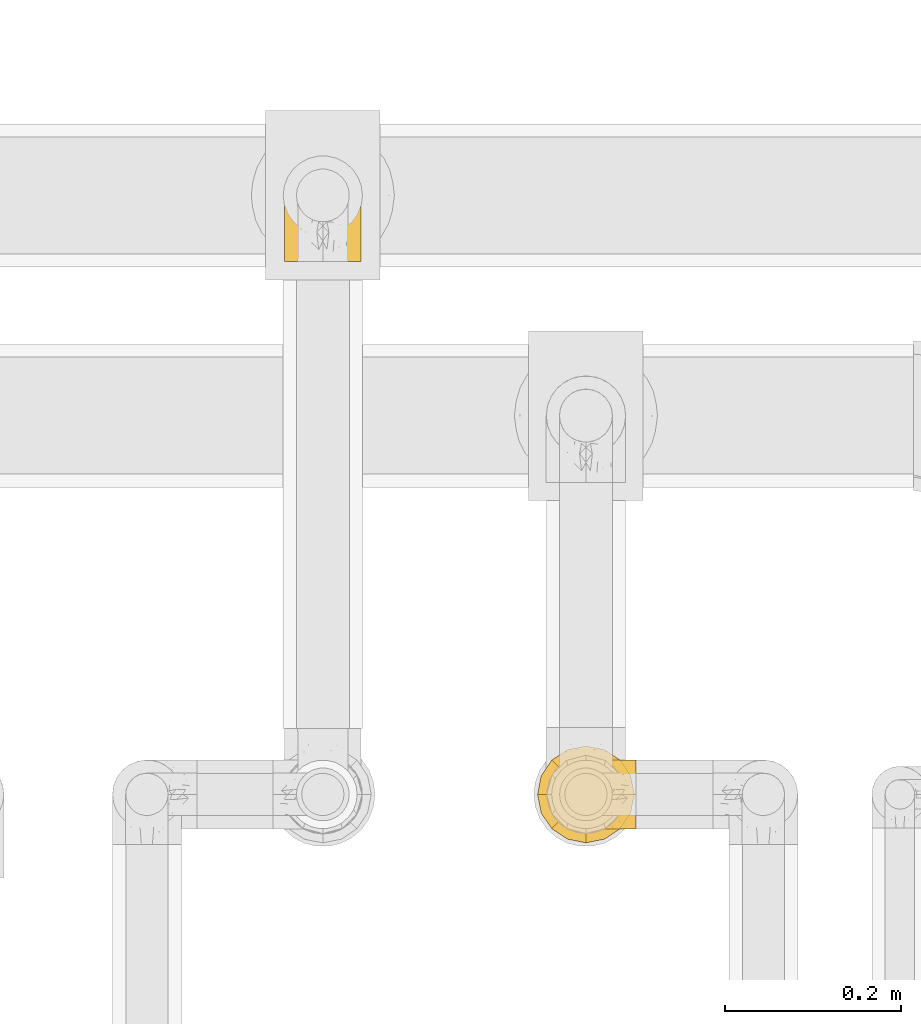
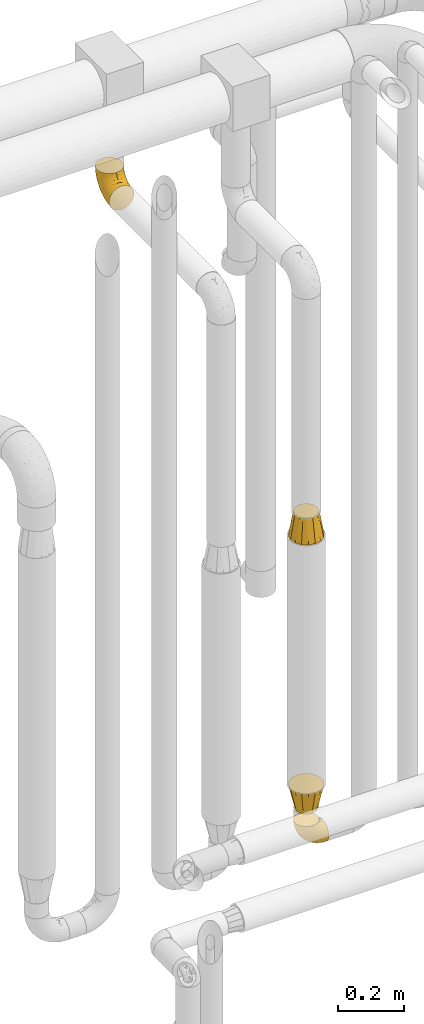
# One storey, part 479 of 827: 4 coverings.
"""IFC2X3 building model written with IfcOpenShell, lengths in millimetres."""

from ifc_helpers import new_model, entity, si_unit, converted_unit, derived_unit, direction, frame, origin, place, context, subcontext, project, spatial, faceted_brep, element, save


model = new_model("IFC2X3")

# Units and contexts
model_context = context("Model", 3, precision=0.01, world=origin(), true_north=direction((6.12303176911189e-17, 1.0)))
body_context = subcontext(model_context, "Body", "Model", "MODEL_VIEW")
ifc_project = project(units=[si_unit("LENGTHUNIT", "METRE", prefix="MILLI"), si_unit("AREAUNIT", "SQUARE_METRE"), si_unit("VOLUMEUNIT", "CUBIC_METRE"), converted_unit("PLANEANGLEUNIT", "DEGREE", entity("IfcRatioMeasure", 0.0174532925199433), si_unit("PLANEANGLEUNIT", "RADIAN"), dimensions=[0, 0, 0, 0, 0, 0, 0]), si_unit("MASSUNIT", "GRAM", prefix="KILO"), derived_unit("MASSDENSITYUNIT", [(si_unit("MASSUNIT", "GRAM", prefix="KILO"), 1), (si_unit("LENGTHUNIT", "METRE"), -3)]), derived_unit("MOMENTOFINERTIAUNIT", [(si_unit("LENGTHUNIT", "METRE"), 4)]), si_unit("TIMEUNIT", "SECOND"), si_unit("FREQUENCYUNIT", "HERTZ"), si_unit("THERMODYNAMICTEMPERATUREUNIT", "DEGREE_CELSIUS"), derived_unit("THERMALTRANSMITTANCEUNIT", [(si_unit("MASSUNIT", "GRAM", prefix="KILO"), 1), (si_unit("THERMODYNAMICTEMPERATUREUNIT", "KELVIN"), -1), (si_unit("TIMEUNIT", "SECOND"), -3)]), derived_unit("VOLUMETRICFLOWRATEUNIT", [(si_unit("LENGTHUNIT", "METRE"), 3), (si_unit("TIMEUNIT", "SECOND"), -1)]), derived_unit("MASSFLOWRATEUNIT", [(si_unit("MASSUNIT", "GRAM", prefix="KILO"), 1), (si_unit("TIMEUNIT", "SECOND"), -1)]), derived_unit("ROTATIONALFREQUENCYUNIT", [(si_unit("TIMEUNIT", "SECOND"), -1)]), si_unit("ELECTRICCURRENTUNIT", "AMPERE"), si_unit("ELECTRICVOLTAGEUNIT", "VOLT"), si_unit("POWERUNIT", "WATT"), si_unit("FORCEUNIT", "NEWTON", prefix="KILO"), si_unit("ILLUMINANCEUNIT", "LUX"), si_unit("LUMINOUSFLUXUNIT", "LUMEN"), si_unit("LUMINOUSINTENSITYUNIT", "CANDELA"), derived_unit("USERDEFINED", [(si_unit("MASSUNIT", "GRAM", prefix="KILO"), -1), (si_unit("LENGTHUNIT", "METRE"), -2), (si_unit("TIMEUNIT", "SECOND"), 3), (si_unit("LUMINOUSFLUXUNIT", "LUMEN"), 1)]), derived_unit("LINEARVELOCITYUNIT", [(si_unit("LENGTHUNIT", "METRE"), 1), (si_unit("TIMEUNIT", "SECOND"), -1)]), si_unit("PRESSUREUNIT", "PASCAL"), derived_unit("USERDEFINED", [(si_unit("LENGTHUNIT", "METRE"), -2), (si_unit("MASSUNIT", "GRAM", prefix="KILO"), 1), (si_unit("TIMEUNIT", "SECOND"), -2)]), derived_unit("LINEARFORCEUNIT", [(si_unit("MASSUNIT", "GRAM", prefix="KILO"), 1), (si_unit("LENGTHUNIT", "METRE"), 1), (si_unit("TIMEUNIT", "SECOND"), -2), (si_unit("LENGTHUNIT", "METRE"), -1)]), derived_unit("PLANARFORCEUNIT", [(si_unit("MASSUNIT", "GRAM", prefix="KILO"), 1), (si_unit("LENGTHUNIT", "METRE"), 1), (si_unit("TIMEUNIT", "SECOND"), -2), (si_unit("LENGTHUNIT", "METRE"), -2)])], contexts=[model_context])

# Site, building, storey
site_placement = place(None, origin())
site = spatial("IfcSite", under=ifc_project, at=site_placement, CompositionType="ELEMENT")
building_placement = place(site_placement, origin())
building = spatial("IfcBuilding", under=site, at=building_placement, CompositionType="ELEMENT")
storey_placement = place(building_placement, frame((0.0, 0.0, 28200.0)))
storey = spatial("IfcBuildingStorey", under=building, at=storey_placement, Name="08", CompositionType="ELEMENT", Elevation=28200.0)

# Coverings
covering_1_placement = place(storey_placement, frame((59555.92, 17459.25, 359.25)))
element("IfcCovering", 1, at=covering_1_placement, inside=storey, Name=":ADSK_", ObjectType=":ADSK_", PredefinedType="INSULATION", context=body_context, shape_type="Brep", body=[
    faceted_brep([(40.75, 79.9, 97.75), (32.03, 78.91, 97.75), (23.75, 76.02, 97.75), (16.33, 71.35, 97.75), (10.13, 65.15, 97.75), (5.47, 57.73, 97.75), (2.58, 49.45, 97.75), (1.6, 40.75, 97.75), (2.58, 32.03, 97.75), (5.48, 23.75, 97.75), (10.14, 16.33, 97.75), (16.34, 10.13, 97.75), (23.76, 5.47, 97.75), (32.04, 2.58, 97.75), (40.75, 1.6, 97.75), (43.94, 1.96, 97.75), (49.46, 2.58, 97.75), (53.6, 4.03, 97.75), (57.74, 5.48, 97.75), (65.16, 10.14, 97.75), (71.36, 16.34, 97.75), (76.02, 23.76, 97.75), (78.91, 32.04, 97.75), (79.9, 40.75, 97.75), (78.91, 49.46, 97.75), (76.02, 57.74, 97.75), (71.35, 65.16, 97.75), (65.15, 71.36, 97.75), (57.73, 76.02, 97.75), (49.45, 78.91, 97.75), (43.94, 79.54, 97.75), (97.75, 13.06, 68.43), (97.75, 6.84, 60.32), (97.75, 2.93, 50.88), (97.75, 2.44, 47.16), (97.75, 2.02, 43.95), (97.75, 1.6, 40.75), (97.75, 2.93, 30.61), (97.75, 6.84, 21.17), (97.75, 13.06, 13.06), (97.75, 21.17, 6.84), (97.75, 30.61, 2.93), (97.75, 40.75, 1.6), (97.75, 50.88, 2.93), (97.75, 60.32, 6.84), (97.75, 68.43, 13.06), (97.75, 74.65, 21.17), (97.75, 78.56, 30.61), (97.75, 79.9, 40.75), (97.75, 79.05, 47.16), (97.75, 78.56, 50.88), (97.75, 74.65, 60.32), (97.75, 68.43, 68.43), (97.75, 60.32, 74.65), (97.75, 50.88, 78.56), (97.75, 40.75, 79.9), (97.75, 30.61, 78.56), (97.75, 21.17, 74.65), (30.59, 40.75, 30.59), (19.96, 40.75, 41.23), (31.39, 53.99, 31.39), (41.23, 40.75, 19.96), (68.03, 40.75, 6.3), (73.86, 47.49, 5.21), (78.49, 40.75, 4.64), (51.06, 51.52, 15.42), (61.05, 61.86, 15.6), (74.96, 54.43, 6.88), (80.64, 63.37, 10.45), (35.94, 79.25, 80.79), (55.44, 77.04, 39.87), (78.19, 75.79, 25.91), (58.08, 72.61, 28.57), (78.4, 78.93, 35.0), (74.65, 70.12, 18.15), (14.61, 66.7, 74.57), (20.05, 72.7, 80.38), (24.25, 70.21, 59.65), (43.81, 78.8, 59.36), (45.08, 79.9, 75.93), (48.17, 79.9, 71.31), (51.26, 79.9, 66.69), (54.35, 79.9, 62.06), (57.44, 79.9, 57.44), (40.25, 74.44, 46.63), (6.22, 52.47, 74.83), (61.23, 79.33, 45.67), (62.06, 79.9, 54.35), (66.69, 79.9, 51.26), (71.31, 79.9, 48.17), (75.93, 79.9, 45.08), (13.08, 48.94, 54.03), (14.98, 58.78, 58.15), (8.5, 60.43, 80.8), (4.64, 40.75, 78.49), (36.67, 62.02, 31.82), (22.97, 57.53, 43.52), (41.46, 79.9, 94.17), (42.17, 79.9, 90.6), (43.59, 79.9, 83.46), (25.24, 64.12, 47.16), (31.25, 75.76, 64.11), (26.96, 76.65, 81.54), (38.0, 68.92, 38.43), (50.65, 66.73, 25.45), (54.63, 40.75, 13.13), (6.3, 40.75, 68.03), (83.46, 79.9, 43.59), (87.03, 79.9, 42.88), (90.6, 79.9, 42.17), (13.13, 40.75, 54.63), (91.79, 63.86, 73.05), (87.2, 69.15, 69.6), (87.5, 78.65, 51.66), (89.79, 72.98, 63.89), (88.45, 76.47, 57.82), (81.77, 76.82, 59.13), (79.81, 79.05, 52.25), (73.84, 79.09, 54.86), (91.84, 51.28, 79.38), (86.62, 51.03, 82.07), (85.12, 40.75, 85.12), (91.15, 40.75, 82.63), (80.84, 49.93, 89.2), (78.96, 58.53, 86.06), (71.38, 69.86, 81.78), (76.81, 65.19, 81.63), (74.29, 70.75, 76.19), (48.29, 79.25, 90.86), (49.97, 79.11, 85.89), (92.85, 57.89, 76.5), (77.55, 55.93, 92.32), (62.05, 78.06, 70.11), (70.85, 75.39, 69.83), (65.52, 78.16, 65.67), (80.71, 66.62, 76.0), (77.97, 73.14, 68.84), (66.14, 71.07, 91.37), (57.01, 78.32, 76.37), (64.57, 73.93, 83.17), (56.53, 77.25, 85.98), (51.07, 79.26, 79.95), (81.85, 60.3, 81.01), (82.63, 40.75, 91.15), (72.53, 65.72, 88.52), (67.69, 74.5, 75.86), (86.44, 60.62, 77.41), (82.44, 73.96, 64.86), (75.97, 77.3, 60.69), (70.39, 77.83, 62.7), (92.85, 23.6, 76.5), (88.99, 17.57, 73.85), (41.46, 1.6, 94.17), (42.17, 1.6, 90.6), (43.59, 1.6, 83.46), (80.84, 31.57, 89.2), (78.97, 22.97, 86.06), (77.55, 25.57, 92.32), (72.54, 15.78, 88.52), (83.46, 1.6, 43.59), (90.6, 1.6, 42.17), (94.17, 1.6, 41.46), (87.2, 12.34, 69.6), (82.6, 7.57, 64.84), (89.34, 8.85, 64.5), (80.74, 2.63, 52.81), (81.77, 4.67, 59.13), (74.04, 2.36, 54.5), (75.93, 1.6, 45.08), (87.5, 2.84, 51.66), (51.07, 2.24, 79.95), (48.17, 1.6, 71.31), (57.03, 3.18, 76.38), (74.31, 10.74, 76.18), (80.61, 15.18, 76.44), (77.09, 16.42, 81.43), (91.84, 30.21, 79.38), (79.19, 9.98, 70.71), (86.62, 30.46, 82.07), (66.15, 10.43, 91.37), (71.84, 12.05, 81.89), (56.55, 4.24, 85.98), (64.59, 7.56, 83.17), (62.05, 3.43, 70.11), (49.99, 2.38, 85.9), (45.08, 1.6, 75.93), (70.39, 3.66, 62.7), (76.36, 4.45, 61.23), (67.71, 6.98, 75.83), (70.92, 6.12, 69.82), (89.33, 5.38, 58.44), (82.04, 21.58, 81.13), (51.26, 1.6, 66.69), (86.44, 20.87, 77.41), (65.56, 3.35, 65.71), (62.06, 1.6, 54.35), (57.44, 1.6, 57.44), (54.35, 1.6, 62.06), (71.31, 1.6, 48.17), (66.69, 1.6, 51.26), (61.23, 2.16, 45.67), (74.65, 11.37, 18.15), (78.19, 5.7, 25.91), (58.07, 8.88, 28.58), (38.01, 12.57, 38.43), (40.25, 7.04, 46.64), (24.26, 11.27, 59.66), (25.25, 17.36, 47.16), (43.81, 2.69, 59.36), (78.4, 2.56, 35.0), (73.86, 34.0, 5.21), (74.96, 27.06, 6.88), (55.45, 4.45, 39.88), (31.26, 5.73, 64.12), (80.64, 18.12, 10.45), (61.05, 19.63, 15.6), (31.39, 27.49, 31.39), (36.69, 19.46, 31.82), (35.95, 2.24, 80.8), (6.22, 29.01, 74.83), (14.62, 14.78, 74.57), (13.09, 32.55, 54.02), (20.06, 8.78, 80.38), (51.06, 29.98, 15.42), (22.97, 23.95, 43.52), (14.99, 22.7, 58.15), (8.51, 21.05, 80.8), (50.64, 14.75, 25.47), (26.97, 4.84, 81.54)], [[[0, 1, 2, 3, 4, 5, 6, 7, 8, 9, 10, 11, 12, 13, 14, 15, 16, 17, 18, 19, 20, 21, 22, 23, 24, 25, 26, 27, 28, 29, 30]], [[31, 32, 33, 34, 35, 36, 37, 38, 39, 40, 41, 42, 43, 44, 45, 46, 47, 48, 49, 50, 51, 52, 53, 54, 55, 56, 57]], [[58, 59, 60, 61]], [[62, 63, 64]], [[65, 66, 67]], [[67, 66, 68]], [[69, 1, 0]], [[70, 71, 72]], [[44, 43, 67]], [[47, 71, 73]], [[45, 74, 46]], [[68, 45, 44]], [[75, 76, 77]], [[76, 3, 2]], [[78, 79, 80, 81, 82, 83]], [[48, 47, 73]], [[70, 72, 84]], [[5, 85, 6]], [[86, 83, 87, 88, 89, 90]], [[91, 85, 92]], [[76, 75, 3]], [[71, 46, 74]], [[85, 5, 93]], [[45, 68, 74]], [[5, 4, 93]], [[85, 94, 6]], [[86, 78, 83]], [[60, 95, 65]], [[96, 95, 60]], [[75, 4, 3]], [[69, 0, 97, 98, 99, 79]], [[75, 77, 100]], [[43, 64, 63]], [[101, 102, 69]], [[101, 76, 102]], [[46, 71, 47]], [[95, 103, 104]], [[92, 85, 93]], [[63, 105, 65]], [[92, 75, 100]], [[91, 106, 85]], [[84, 78, 70]], [[67, 68, 44]], [[65, 67, 63]], [[65, 61, 60]], [[4, 75, 93]], [[92, 93, 75]], [[102, 76, 2]], [[77, 76, 101]], [[84, 77, 101]], [[77, 103, 100]], [[72, 71, 74]], [[70, 86, 73]], [[104, 74, 66]], [[84, 72, 103]], [[70, 73, 71]], [[73, 90, 107, 108, 109, 48]], [[79, 78, 69]], [[101, 69, 78]], [[91, 92, 96]], [[91, 59, 110, 106]], [[2, 1, 102]], [[69, 102, 1]], [[94, 85, 106]], [[94, 7, 6]], [[74, 68, 66]], [[43, 42, 64]], [[43, 63, 67]], [[73, 86, 90]], [[78, 86, 70]], [[95, 100, 103]], [[96, 92, 100]], [[104, 103, 72]], [[65, 95, 66]], [[74, 104, 72]], [[66, 95, 104]], [[95, 96, 100]], [[91, 96, 60]], [[77, 84, 103]], [[78, 84, 101]], [[60, 59, 91]], [[105, 63, 62]], [[105, 61, 65]], [[111, 52, 112]], [[107, 90, 113]], [[114, 115, 116]], [[50, 107, 113]], [[117, 118, 116]], [[54, 119, 55]], [[97, 0, 30, 29, 98]], [[113, 115, 51]], [[120, 121, 122]], [[123, 120, 124]], [[125, 126, 127]], [[128, 28, 129]], [[130, 54, 53]], [[25, 24, 131]], [[132, 133, 134]], [[135, 112, 136]], [[137, 27, 26]], [[121, 120, 123]], [[138, 139, 132]], [[129, 140, 141]], [[135, 126, 142]], [[27, 140, 28]], [[27, 137, 140]], [[49, 48, 109, 108, 107, 50]], [[23, 143, 121, 123]], [[25, 131, 144]], [[26, 25, 144]], [[128, 98, 29]], [[125, 127, 145]], [[146, 130, 111]], [[137, 144, 139]], [[139, 138, 140]], [[116, 147, 114]], [[123, 124, 131]], [[116, 118, 148]], [[134, 83, 82]], [[129, 79, 99]], [[54, 130, 119]], [[141, 79, 129]], [[122, 55, 119]], [[120, 146, 142]], [[117, 113, 90]], [[50, 113, 51]], [[127, 133, 145]], [[147, 136, 112]], [[136, 133, 127]], [[24, 23, 123]], [[118, 117, 89]], [[149, 87, 134]], [[144, 131, 124]], [[24, 123, 131]], [[128, 129, 99]], [[28, 140, 129]], [[144, 137, 26]], [[140, 137, 139]], [[81, 138, 132]], [[138, 80, 141]], [[89, 88, 87, 118]], [[115, 117, 116]], [[140, 138, 141]], [[148, 118, 149]], [[136, 148, 149]], [[147, 116, 148]], [[133, 136, 149]], [[127, 126, 135]], [[136, 147, 148]], [[114, 112, 52]], [[112, 114, 147]], [[51, 114, 52]], [[51, 115, 114]], [[117, 115, 113]], [[117, 90, 89]], [[134, 133, 149]], [[145, 133, 132]], [[132, 139, 145]], [[125, 139, 144]], [[139, 125, 145]], [[126, 144, 124]], [[144, 126, 125]], [[142, 126, 124]], [[120, 142, 124]], [[142, 146, 135]], [[112, 135, 146]], [[136, 127, 135]], [[118, 87, 149]], [[82, 81, 132]], [[111, 130, 53]], [[119, 146, 120]], [[146, 119, 130]], [[122, 119, 120]], [[52, 111, 53]], [[146, 111, 112]], [[134, 82, 132]], [[83, 134, 87]], [[98, 128, 99]], [[80, 138, 81]], [[80, 79, 141]], [[28, 128, 29]], [[150, 151, 57]], [[15, 14, 152, 153, 154, 16]], [[121, 143, 23, 155]], [[150, 57, 56]], [[156, 157, 158]], [[35, 34, 33, 159, 160, 161, 36]], [[162, 31, 57]], [[163, 164, 162]], [[165, 166, 167]], [[155, 23, 22]], [[168, 159, 169]], [[170, 171, 172]], [[173, 174, 175]], [[55, 122, 176]], [[177, 174, 173]], [[22, 157, 155]], [[178, 121, 155]], [[169, 33, 32]], [[20, 19, 179]], [[21, 20, 158]], [[158, 180, 175]], [[181, 182, 179]], [[172, 183, 182]], [[122, 121, 178]], [[181, 19, 18]], [[184, 185, 170]], [[17, 154, 184]], [[186, 187, 177]], [[187, 186, 167]], [[179, 158, 20]], [[21, 157, 22]], [[175, 180, 173]], [[188, 189, 173]], [[164, 166, 190]], [[185, 184, 154]], [[181, 172, 182]], [[156, 191, 178]], [[192, 183, 172]], [[178, 176, 122]], [[193, 150, 176]], [[33, 169, 159]], [[190, 169, 32]], [[189, 194, 186]], [[180, 188, 173]], [[167, 166, 187]], [[166, 164, 163]], [[195, 194, 196]], [[158, 157, 21]], [[155, 157, 156]], [[178, 155, 156]], [[181, 18, 184]], [[17, 16, 154]], [[181, 179, 19]], [[158, 179, 182]], [[170, 181, 184]], [[196, 194, 197]], [[31, 190, 32]], [[165, 190, 166]], [[190, 31, 164]], [[31, 162, 164]], [[177, 163, 162]], [[187, 166, 163]], [[151, 174, 177]], [[177, 173, 189]], [[177, 187, 163]], [[195, 167, 186]], [[165, 198, 168]], [[165, 168, 169]], [[167, 198, 165]], [[190, 165, 169]], [[167, 195, 199, 198]], [[151, 177, 162]], [[175, 191, 156]], [[191, 174, 193]], [[158, 175, 156]], [[174, 191, 175]], [[178, 191, 193]], [[158, 182, 180]], [[188, 182, 183]], [[182, 188, 180]], [[183, 194, 189]], [[183, 189, 188]], [[177, 189, 186]], [[194, 183, 197]], [[176, 150, 56]], [[151, 150, 193]], [[176, 56, 55]], [[193, 176, 178]], [[174, 151, 193]], [[57, 151, 162]], [[183, 192, 197]], [[194, 195, 186]], [[171, 192, 172]], [[172, 181, 170]], [[170, 185, 171]], [[184, 18, 17]], [[200, 168, 198, 199, 195, 196]], [[201, 202, 203]], [[204, 203, 205]], [[204, 206, 207]], [[208, 196, 197, 192, 171, 185]], [[209, 36, 161, 160, 159, 168]], [[202, 38, 37]], [[201, 38, 202]], [[210, 41, 211]], [[200, 208, 212]], [[205, 208, 213]], [[214, 211, 40]], [[40, 211, 41]], [[214, 201, 215]], [[58, 61, 216, 59]], [[201, 39, 38]], [[207, 217, 204]], [[213, 208, 218]], [[218, 185, 154, 153, 152, 14]], [[14, 13, 218]], [[9, 8, 219]], [[10, 220, 11]], [[221, 106, 110, 59]], [[219, 8, 94]], [[220, 222, 11]], [[223, 211, 215]], [[221, 216, 224]], [[225, 219, 221]], [[10, 9, 226]], [[213, 222, 206]], [[226, 9, 219]], [[106, 219, 94]], [[212, 202, 209]], [[201, 203, 227]], [[226, 225, 220]], [[207, 206, 220]], [[214, 40, 39]], [[11, 222, 12]], [[12, 222, 228]], [[41, 210, 64]], [[223, 105, 210]], [[223, 215, 217]], [[105, 62, 210]], [[206, 222, 220]], [[228, 222, 213]], [[207, 220, 225]], [[205, 206, 204]], [[225, 226, 219]], [[220, 10, 226]], [[209, 202, 37]], [[203, 202, 212]], [[205, 203, 212]], [[204, 217, 227]], [[36, 209, 37]], [[209, 168, 200]], [[218, 13, 228]], [[208, 185, 218]], [[106, 221, 219]], [[221, 59, 216]], [[218, 228, 213]], [[13, 12, 228]], [[8, 7, 94]], [[201, 214, 39]], [[211, 214, 215]], [[64, 210, 62]], [[64, 42, 41]], [[223, 210, 211]], [[208, 200, 196]], [[209, 200, 212]], [[225, 224, 207]], [[207, 224, 217]], [[223, 217, 216]], [[204, 227, 203]], [[217, 215, 227]], [[201, 227, 215]], [[221, 224, 225]], [[217, 224, 216]], [[208, 205, 212]], [[206, 205, 213]], [[216, 61, 223]], [[223, 61, 105]]]),
])
covering_2_placement = place(storey_placement, frame((59540.07, 17443.4, 1513.24)))
element("IfcCovering", 2, at=covering_2_placement, inside=storey, Name=":ADSK_", ObjectType=":ADSK_", PredefinedType="INSULATION", context=body_context, shape_type="Brep", body=[
    faceted_brep([(77.64, 5.78, 0.0), (67.12, 3.69, 0.0), (56.6, 1.6, 0.0), (46.07, 3.69, 0.0), (35.55, 5.78, 0.0), (26.63, 11.74, 0.0), (17.7, 17.7, 0.0), (11.74, 26.63, 0.0), (5.78, 35.55, 0.0), (3.69, 46.07, 0.0), (1.6, 56.6, 0.0), (3.69, 67.12, 0.0), (5.78, 77.64, 0.0), (11.74, 86.56, 0.0), (17.7, 95.49, 0.0), (26.63, 101.45, 0.0), (35.55, 107.41, 0.0), (46.07, 109.5, 0.0), (56.6, 111.6, 0.0), (67.12, 109.5, 0.0), (77.64, 107.41, 0.0), (86.56, 101.45, 0.0), (95.49, 95.49, 0.0), (101.45, 86.56, 0.0), (107.41, 77.64, 0.0), (109.5, 67.12, 0.0), (111.6, 56.6, 0.0), (109.5, 46.07, 0.0), (107.41, 35.55, 0.0), (101.45, 26.63, 0.0), (95.49, 17.7, 0.0), (86.56, 11.74, 0.0), (91.24, 76.6, 89.0), (83.92, 83.92, 89.0), (76.6, 91.24, 89.0), (66.6, 93.92, 89.0), (56.6, 96.6, 89.0), (46.6, 93.92, 89.0), (36.6, 91.24, 89.0), (29.27, 83.92, 89.0), (21.95, 76.6, 89.0), (19.27, 66.6, 89.0), (16.6, 56.6, 89.0), (19.27, 46.6, 89.0), (21.95, 36.6, 89.0), (29.27, 29.27, 89.0), (36.6, 21.95, 89.0), (46.6, 19.27, 89.0), (56.6, 16.6, 89.0), (66.6, 19.27, 89.0), (76.6, 21.95, 89.0), (83.92, 29.27, 89.0), (91.24, 36.6, 89.0), (93.92, 46.6, 89.0), (96.6, 56.6, 89.0), (93.92, 66.6, 89.0)], [[[0, 1, 2, 3, 4, 5, 6, 7, 8, 9, 10, 11, 12, 13, 14, 15, 16, 17, 18, 19, 20, 21, 22, 23, 24, 25, 26, 27, 28, 29, 30, 31]], [[32, 33, 34, 35, 36, 37, 38, 39, 40, 41, 42, 43, 44, 45, 46, 47, 48, 49, 50, 51, 52, 53, 54, 55]], [[3, 2, 48]], [[44, 7, 45]], [[45, 5, 46]], [[48, 47, 3]], [[6, 45, 7]], [[44, 8, 7]], [[5, 45, 6]], [[42, 9, 43]], [[5, 4, 46]], [[47, 46, 4]], [[9, 42, 10]], [[8, 44, 43]], [[9, 8, 43]], [[47, 4, 3]], [[11, 10, 42]], [[38, 15, 39]], [[39, 13, 40]], [[42, 41, 11]], [[14, 39, 15]], [[38, 16, 15]], [[13, 39, 14]], [[36, 17, 37]], [[13, 12, 40]], [[41, 40, 12]], [[17, 36, 18]], [[16, 38, 37]], [[17, 16, 37]], [[41, 12, 11]], [[19, 18, 36]], [[32, 23, 33]], [[33, 21, 34]], [[36, 35, 19]], [[22, 33, 23]], [[32, 24, 23]], [[21, 33, 22]], [[54, 25, 55]], [[21, 20, 34]], [[35, 34, 20]], [[25, 54, 26]], [[24, 32, 55]], [[25, 24, 55]], [[35, 20, 19]], [[27, 26, 54]], [[50, 31, 51]], [[51, 29, 52]], [[54, 53, 27]], [[30, 51, 31]], [[50, 0, 31]], [[29, 51, 30]], [[48, 1, 49]], [[29, 28, 52]], [[53, 52, 28]], [[1, 48, 2]], [[0, 50, 49]], [[1, 0, 49]], [[53, 28, 27]]]),
])
covering_3_placement = place(storey_placement, frame((59540.07, 17443.4, 500.0)))
element("IfcCovering", 3, at=covering_3_placement, inside=storey, Name=":ADSK_", ObjectType=":ADSK_", PredefinedType="INSULATION", context=body_context, shape_type="Brep", body=[
    faceted_brep([(91.6, 56.6, 0.0), (89.25, 47.85, 0.0), (86.91, 39.1, 0.0), (80.5, 32.69, 0.0), (74.1, 26.28, 0.0), (65.35, 23.94, 0.0), (56.6, 21.6, 0.0), (47.85, 23.94, 0.0), (39.1, 26.28, 0.0), (32.69, 32.69, 0.0), (26.28, 39.1, 0.0), (23.94, 47.85, 0.0), (21.6, 56.6, 0.0), (23.94, 65.35, 0.0), (26.28, 74.1, 0.0), (32.69, 80.5, 0.0), (39.1, 86.91, 0.0), (47.85, 89.25, 0.0), (56.6, 91.6, 0.0), (65.35, 89.25, 0.0), (74.1, 86.91, 0.0), (80.5, 80.5, 0.0), (86.91, 74.1, 0.0), (89.25, 65.35, 0.0), (1.6, 56.6, 89.0), (3.69, 46.07, 89.0), (5.78, 35.55, 89.0), (11.74, 26.63, 89.0), (17.7, 17.7, 89.0), (26.63, 11.74, 89.0), (35.55, 5.78, 89.0), (46.07, 3.69, 89.0), (56.6, 1.6, 89.0), (67.12, 3.69, 89.0), (77.64, 5.78, 89.0), (86.56, 11.74, 89.0), (95.49, 17.7, 89.0), (101.45, 26.63, 89.0), (107.41, 35.55, 89.0), (109.5, 46.07, 89.0), (111.6, 56.6, 89.0), (109.5, 67.12, 89.0), (107.41, 77.64, 89.0), (101.45, 86.56, 89.0), (95.49, 95.49, 89.0), (86.56, 101.45, 89.0), (77.64, 107.41, 89.0), (67.12, 109.5, 89.0), (56.6, 111.6, 89.0), (46.07, 109.5, 89.0), (35.55, 107.41, 89.0), (26.63, 101.45, 89.0), (17.7, 95.49, 89.0), (11.74, 86.56, 89.0), (5.78, 77.64, 89.0), (3.69, 67.12, 89.0)], [[[0, 1, 2, 3, 4, 5, 6, 7, 8, 9, 10, 11, 12, 13, 14, 15, 16, 17, 18, 19, 20, 21, 22, 23]], [[24, 25, 26, 27, 28, 29, 30, 31, 32, 33, 34, 35, 36, 37, 38, 39, 40, 41, 42, 43, 44, 45, 46, 47, 48, 49, 50, 51, 52, 53, 54, 55]], [[33, 32, 6]], [[2, 38, 37]], [[35, 34, 4]], [[35, 4, 3]], [[2, 37, 3]], [[35, 3, 36]], [[39, 38, 1]], [[6, 5, 33]], [[37, 36, 3]], [[0, 39, 1]], [[5, 4, 34]], [[39, 0, 40]], [[38, 2, 1]], [[5, 34, 33]], [[25, 24, 12]], [[8, 30, 29]], [[27, 26, 10]], [[27, 10, 9]], [[8, 29, 9]], [[27, 9, 28]], [[31, 30, 7]], [[12, 11, 25]], [[29, 28, 9]], [[6, 31, 7]], [[11, 10, 26]], [[31, 6, 32]], [[30, 8, 7]], [[11, 26, 25]], [[49, 48, 18]], [[14, 54, 53]], [[51, 50, 16]], [[51, 16, 15]], [[14, 53, 15]], [[51, 15, 52]], [[55, 54, 13]], [[18, 17, 49]], [[53, 52, 15]], [[12, 55, 13]], [[17, 16, 50]], [[55, 12, 24]], [[54, 14, 13]], [[17, 50, 49]], [[41, 40, 0]], [[20, 46, 45]], [[43, 42, 22]], [[43, 22, 21]], [[20, 45, 21]], [[43, 21, 44]], [[47, 46, 19]], [[0, 23, 41]], [[45, 44, 21]], [[18, 47, 19]], [[23, 22, 42]], [[47, 18, 48]], [[46, 20, 19]], [[23, 42, 41]]]),
])
covering_4_placement = place(storey_placement, frame((59252.8, 18103.5, 2457.15)))
element("IfcCovering", 4, at=covering_4_placement, inside=storey, Name=":ADSK_", ObjectType=":ADSK_", PredefinedType="INSULATION", context=body_context, shape_type="Brep", body=[
    faceted_brep([(2.69, 1.6, 35.41), (5.91, 1.6, 26.21), (11.09, 1.6, 17.97), (17.98, 1.6, 11.08), (26.23, 1.6, 5.9), (35.42, 1.6, 2.68), (45.1, 1.6, 1.6), (54.78, 1.6, 2.69), (63.98, 1.6, 5.91), (72.22, 1.6, 11.09), (79.11, 1.6, 17.98), (84.29, 1.6, 26.23), (87.51, 1.6, 35.42), (88.6, 1.6, 45.1), (87.5, 1.6, 54.78), (84.28, 1.6, 63.98), (79.1, 1.6, 72.22), (72.21, 1.6, 79.11), (63.96, 1.6, 84.29), (54.77, 1.6, 87.51), (45.1, 1.6, 88.6), (35.41, 1.6, 87.5), (26.21, 1.6, 84.28), (17.97, 1.6, 79.1), (11.08, 1.6, 72.21), (5.9, 1.6, 63.96), (2.68, 1.6, 54.77), (1.6, 1.6, 45.1), (56.35, 34.58, 120.1), (66.85, 38.92, 120.1), (75.85, 45.84, 120.1), (82.77, 54.85, 120.1), (87.11, 65.34, 120.1), (88.6, 76.6, 120.1), (87.11, 87.85, 120.1), (82.77, 98.35, 120.1), (75.85, 107.35, 120.1), (66.85, 114.27, 120.1), (56.35, 118.61, 120.1), (45.1, 120.1, 120.1), (33.84, 118.61, 120.1), (23.35, 114.27, 120.1), (14.34, 107.35, 120.1), (7.42, 98.35, 120.1), (3.08, 87.85, 120.1), (1.6, 76.6, 120.1), (3.08, 65.34, 120.1), (7.42, 54.85, 120.1), (14.34, 45.84, 120.1), (23.35, 38.92, 120.1), (33.84, 34.58, 120.1), (45.1, 33.1, 120.1), (45.1, 71.25, 24.23), (36.91, 75.4, 28.38), (45.1, 84.36, 37.33), (45.1, 114.3, 83.48), (37.59, 115.98, 91.73), (45.1, 116.71, 98.7), (32.61, 102.85, 62.13), (30.31, 83.56, 38.14), (20.95, 87.75, 49.82), (29.76, 113.63, 91.17), (21.38, 102.76, 73.3), (19.86, 109.82, 98.13), (2.26, 22.49, 40.2), (13.53, 91.7, 66.33), (6.95, 88.22, 78.94), (12.17, 101.35, 92.75), (2.76, 50.56, 50.64), (6.44, 66.04, 50.37), (5.9, 42.48, 35.59), (16.04, 30.27, 16.62), (9.44, 23.11, 22.51), (12.02, 49.11, 28.43), (1.6, 30.3, 50.8), (1.6, 42.46, 58.93), (1.6, 54.63, 67.06), (2.42, 82.19, 98.53), (5.74, 93.26, 101.45), (35.62, 56.17, 16.09), (45.1, 38.21, 7.4), (31.92, 30.03, 7.16), (1.6, 70.89, 91.39), (1.6, 72.69, 100.45), (1.6, 74.49, 109.5), (24.69, 50.45, 17.74), (3.07, 71.95, 70.23), (23.09, 22.72, 9.57), (45.1, 22.99, 4.98), (1.6, 12.19, 47.2), (1.6, 21.24, 49.0), (17.83, 49.42, 22.26), (45.1, 97.46, 50.44), (1.6, 62.76, 79.23), (4.82, 20.75, 30.68), (20.17, 68.34, 31.84), (13.03, 73.75, 44.66), (45.1, 105.88, 66.96), (29.38, 66.96, 24.8), (45.1, 54.73, 15.81), (26.52, 19.37, 89.18), (35.72, 15.82, 90.85), (32.72, 26.46, 97.95), (2.51, 62.01, 93.22), (3.24, 62.98, 105.29), (21.78, 29.13, 93.5), (13.34, 33.41, 87.89), (17.18, 24.14, 85.09), (3.92, 39.09, 72.04), (3.4, 50.73, 81.31), (5.08, 25.51, 67.33), (3.12, 34.57, 65.71), (2.52, 29.47, 60.17), (3.16, 56.24, 87.89), (5.61, 53.44, 97.01), (2.51, 18.75, 56.24), (8.14, 52.63, 109.86), (34.28, 31.88, 107.34), (45.1, 28.88, 104.35), (14.76, 43.08, 105.97), (5.23, 16.65, 64.5), (26.55, 36.44, 112.57), (24.2, 34.31, 103.13), (28.76, 9.97, 86.44), (18.44, 14.45, 81.56), (11.87, 10.88, 74.09), (9.55, 47.02, 99.39), (14.85, 38.6, 96.78), (2.24, 11.66, 53.3), (9.22, 22.03, 74.03), (10.3, 29.39, 79.87), (45.1, 11.98, 91.38), (45.1, 17.35, 92.82), (8.47, 44.11, 90.97), (7.24, 38.88, 81.62), (45.1, 23.11, 98.58), (45.1, 30.31, 109.71), (75.43, 43.08, 105.98), (80.64, 47.02, 99.39), (75.33, 38.6, 96.79), (81.72, 44.1, 90.97), (55.91, 31.89, 107.35), (78.31, 10.87, 74.11), (88.6, 21.24, 49.0), (87.68, 18.75, 56.25), (87.95, 11.66, 53.3), (54.46, 15.82, 90.85), (63.65, 19.36, 89.18), (57.46, 26.47, 97.96), (85.1, 25.52, 67.35), (80.96, 22.02, 74.04), (84.95, 16.64, 64.52), (63.63, 36.44, 112.57), (88.6, 72.69, 100.45), (88.6, 74.49, 109.5), (79.88, 29.37, 79.88), (72.99, 24.13, 85.1), (82.05, 52.63, 109.86), (86.95, 62.98, 105.29), (88.6, 70.89, 91.39), (76.84, 33.4, 87.9), (68.39, 29.12, 93.52), (61.41, 9.97, 86.44), (88.6, 42.46, 58.93), (88.6, 54.63, 67.06), (86.26, 39.09, 72.04), (88.6, 12.19, 47.2), (71.74, 14.44, 81.57), (87.68, 62.01, 93.22), (87.03, 56.24, 87.89), (88.6, 62.76, 79.23), (87.67, 29.48, 60.18), (86.79, 50.73, 81.31), (82.94, 38.86, 81.63), (88.6, 30.3, 50.8), (84.58, 53.44, 97.01), (65.99, 34.31, 103.14), (68.81, 102.75, 73.27), (78.02, 101.35, 92.75), (76.67, 91.7, 66.34), (69.25, 87.73, 49.8), (83.24, 88.22, 78.94), (87.12, 71.95, 70.23), (83.76, 66.01, 50.35), (70.03, 68.32, 31.83), (59.89, 83.55, 38.14), (84.45, 93.26, 101.45), (87.77, 82.19, 98.53), (57.57, 102.84, 62.12), (60.43, 113.63, 91.16), (52.6, 115.98, 91.73), (87.43, 50.56, 50.64), (84.29, 42.46, 35.6), (70.33, 109.82, 98.12), (87.93, 22.48, 40.21), (58.28, 30.03, 7.17), (74.16, 30.26, 16.63), (54.58, 56.17, 16.09), (80.75, 23.11, 22.53), (65.51, 50.44, 17.74), (60.83, 66.95, 24.8), (67.11, 22.72, 9.58), (78.18, 49.11, 28.44), (72.37, 49.42, 22.27), (85.37, 20.74, 30.69), (77.18, 73.72, 44.64), (53.29, 75.39, 28.37)], [[[0, 1, 2, 3, 4, 5, 6, 7, 8, 9, 10, 11, 12, 13, 14, 15, 16, 17, 18, 19, 20, 21, 22, 23, 24, 25, 26, 27]], [[28, 29, 30, 31, 32, 33, 34, 35, 36, 37, 38, 39, 40, 41, 42, 43, 44, 45, 46, 47, 48, 49, 50, 51]], [[52, 53, 54]], [[55, 56, 57]], [[58, 59, 60]], [[61, 62, 63]], [[27, 64, 0]], [[65, 66, 67]], [[41, 40, 61]], [[68, 69, 70]], [[67, 43, 42]], [[63, 42, 41]], [[71, 72, 73]], [[72, 2, 1]], [[68, 74, 75, 76]], [[45, 44, 77]], [[43, 78, 44]], [[79, 80, 81]], [[77, 82, 83, 84, 45]], [[79, 81, 85]], [[71, 2, 72]], [[66, 86, 77]], [[4, 81, 5]], [[67, 66, 78]], [[4, 3, 87]], [[81, 88, 5]], [[66, 65, 69]], [[65, 67, 62]], [[62, 60, 65]], [[71, 3, 2]], [[64, 27, 89, 90, 74]], [[91, 71, 73]], [[40, 57, 56]], [[59, 92, 54]], [[86, 76, 93, 82]], [[1, 0, 94]], [[58, 62, 61]], [[60, 95, 96]], [[85, 81, 87]], [[56, 97, 58]], [[63, 67, 42]], [[87, 81, 4]], [[68, 70, 64]], [[64, 94, 0]], [[94, 72, 1]], [[73, 72, 70]], [[69, 73, 70]], [[73, 96, 95]], [[3, 71, 87]], [[85, 87, 71]], [[58, 61, 56]], [[59, 58, 92]], [[76, 86, 68]], [[69, 96, 73]], [[68, 86, 69]], [[66, 69, 86]], [[68, 64, 74]], [[94, 64, 70]], [[98, 79, 85]], [[79, 52, 99, 80]], [[62, 58, 60]], [[69, 65, 96]], [[59, 98, 95]], [[96, 65, 60]], [[61, 63, 41]], [[67, 63, 62]], [[59, 95, 60]], [[95, 85, 91]], [[88, 81, 80]], [[88, 6, 5]], [[72, 94, 70]], [[77, 44, 78]], [[86, 82, 77]], [[40, 39, 57]], [[95, 98, 85]], [[40, 56, 61]], [[67, 78, 43]], [[77, 78, 66]], [[79, 98, 53]], [[95, 91, 73]], [[85, 71, 91]], [[97, 56, 55]], [[97, 92, 58]], [[53, 98, 59]], [[54, 53, 59]], [[79, 53, 52]], [[100, 101, 102]], [[46, 45, 84, 83]], [[103, 104, 82]], [[82, 104, 83]], [[105, 106, 107]], [[108, 109, 76]], [[110, 111, 112]], [[103, 113, 114]], [[112, 74, 115]], [[48, 47, 116]], [[117, 102, 118]], [[49, 48, 119]], [[75, 108, 76]], [[115, 25, 120]], [[49, 121, 50]], [[122, 105, 102]], [[123, 124, 22]], [[115, 74, 90]], [[23, 22, 124]], [[24, 125, 120]], [[119, 126, 127]], [[89, 26, 128]], [[27, 26, 89]], [[120, 110, 112]], [[24, 120, 25]], [[125, 124, 129]], [[130, 107, 106]], [[21, 20, 131]], [[119, 122, 121]], [[129, 107, 130]], [[50, 117, 51]], [[21, 123, 22]], [[101, 131, 132]], [[116, 119, 48]], [[24, 23, 125]], [[126, 114, 133]], [[128, 25, 115]], [[106, 134, 130]], [[133, 114, 113]], [[115, 90, 128]], [[112, 115, 120]], [[120, 129, 110]], [[75, 74, 112]], [[101, 135, 102]], [[131, 101, 21]], [[101, 100, 123]], [[127, 126, 133]], [[118, 136, 51, 117]], [[104, 47, 46]], [[83, 104, 46]], [[116, 104, 114]], [[101, 123, 21]], [[124, 123, 100]], [[102, 117, 122]], [[124, 125, 23]], [[120, 125, 129]], [[133, 134, 106]], [[134, 109, 108]], [[114, 104, 103]], [[93, 76, 109]], [[133, 106, 127]], [[104, 116, 47]], [[116, 114, 126]], [[121, 117, 50]], [[109, 134, 133]], [[130, 108, 129]], [[108, 130, 134]], [[107, 129, 124]], [[124, 100, 107]], [[105, 122, 127]], [[107, 100, 105]], [[102, 105, 100]], [[89, 128, 90]], [[25, 128, 26]], [[82, 93, 103]], [[113, 93, 109]], [[105, 127, 106]], [[122, 119, 127]], [[119, 121, 49]], [[117, 121, 122]], [[93, 113, 103]], [[133, 113, 109]], [[129, 108, 110]], [[111, 110, 108]], [[108, 75, 111]], [[75, 112, 111]], [[135, 101, 132]], [[135, 118, 102]], [[116, 126, 119]], [[30, 29, 137]], [[138, 139, 140]], [[51, 136, 118, 141]], [[142, 17, 16]], [[143, 144, 145]], [[146, 147, 148]], [[149, 150, 151]], [[152, 29, 28]], [[33, 32, 153, 154]], [[150, 155, 156]], [[157, 31, 30]], [[153, 158, 159]], [[29, 152, 137]], [[148, 141, 118]], [[160, 161, 156]], [[148, 135, 146]], [[137, 138, 157]], [[19, 162, 146]], [[163, 164, 165]], [[14, 13, 166]], [[153, 32, 158]], [[147, 162, 167]], [[18, 17, 167]], [[168, 169, 170]], [[167, 150, 156]], [[151, 150, 142]], [[151, 171, 149]], [[151, 16, 15]], [[172, 140, 173]], [[166, 143, 145]], [[144, 143, 174]], [[142, 167, 17]], [[19, 131, 20]], [[144, 171, 151]], [[18, 162, 19]], [[14, 145, 15]], [[140, 139, 160]], [[172, 165, 164]], [[165, 173, 155]], [[171, 144, 174]], [[15, 144, 151]], [[174, 163, 171]], [[165, 171, 163]], [[19, 146, 131]], [[132, 131, 146]], [[161, 148, 147]], [[151, 142, 16]], [[135, 132, 146]], [[158, 32, 31]], [[157, 158, 31]], [[168, 158, 175]], [[167, 162, 18]], [[146, 162, 147]], [[148, 176, 141]], [[167, 142, 150]], [[159, 158, 168]], [[172, 169, 140]], [[172, 164, 170]], [[138, 140, 175]], [[173, 140, 160]], [[137, 157, 30]], [[158, 157, 175]], [[152, 141, 176]], [[51, 141, 28]], [[155, 173, 160]], [[172, 173, 165]], [[155, 160, 156]], [[165, 155, 150]], [[160, 139, 161]], [[147, 167, 156]], [[148, 161, 176]], [[147, 156, 161]], [[15, 145, 144]], [[166, 145, 14]], [[169, 168, 175]], [[170, 159, 168]], [[137, 176, 139]], [[161, 139, 176]], [[141, 152, 28]], [[137, 152, 176]], [[140, 169, 175]], [[170, 169, 172]], [[171, 165, 149]], [[165, 150, 149]], [[148, 118, 135]], [[157, 138, 175]], [[139, 138, 137]], [[177, 178, 179]], [[177, 179, 180]], [[181, 182, 183]], [[184, 185, 180]], [[186, 187, 181]], [[187, 33, 154, 153, 159]], [[177, 188, 189]], [[35, 34, 186]], [[190, 38, 189]], [[191, 192, 183]], [[191, 164, 163, 174]], [[193, 189, 37]], [[37, 189, 38]], [[36, 35, 178]], [[54, 92, 185]], [[35, 186, 178]], [[193, 178, 177]], [[194, 174, 143, 166, 13]], [[194, 191, 174]], [[179, 178, 181]], [[13, 12, 194]], [[8, 7, 195]], [[9, 196, 10]], [[197, 80, 99, 52]], [[195, 7, 88]], [[196, 198, 10]], [[180, 188, 177]], [[199, 197, 200]], [[199, 195, 197]], [[9, 8, 201]], [[192, 198, 202]], [[193, 37, 36]], [[80, 195, 88]], [[182, 159, 170, 164]], [[187, 34, 33]], [[201, 199, 196]], [[184, 202, 203]], [[201, 8, 195]], [[10, 198, 11]], [[12, 11, 204]], [[38, 190, 57]], [[188, 97, 190]], [[202, 198, 196]], [[204, 198, 192]], [[203, 202, 196]], [[183, 202, 205]], [[199, 201, 195]], [[196, 9, 201]], [[206, 54, 185]], [[97, 55, 190]], [[192, 202, 183]], [[182, 164, 191]], [[183, 205, 179]], [[182, 191, 183]], [[204, 194, 12]], [[191, 194, 192]], [[80, 197, 195]], [[206, 185, 200]], [[183, 179, 181]], [[180, 185, 188]], [[179, 205, 180]], [[184, 180, 205]], [[178, 193, 36]], [[189, 193, 177]], [[202, 184, 205]], [[184, 199, 200]], [[7, 6, 88]], [[198, 204, 11]], [[194, 204, 192]], [[159, 182, 187]], [[181, 187, 182]], [[57, 190, 55]], [[57, 39, 38]], [[188, 190, 189]], [[187, 186, 34]], [[178, 186, 181]], [[185, 92, 188]], [[196, 199, 203]], [[184, 203, 199]], [[188, 92, 97]], [[206, 197, 52]], [[184, 200, 185]], [[197, 206, 200]], [[54, 206, 52]]]),
])

save(model, "model.ifc")
